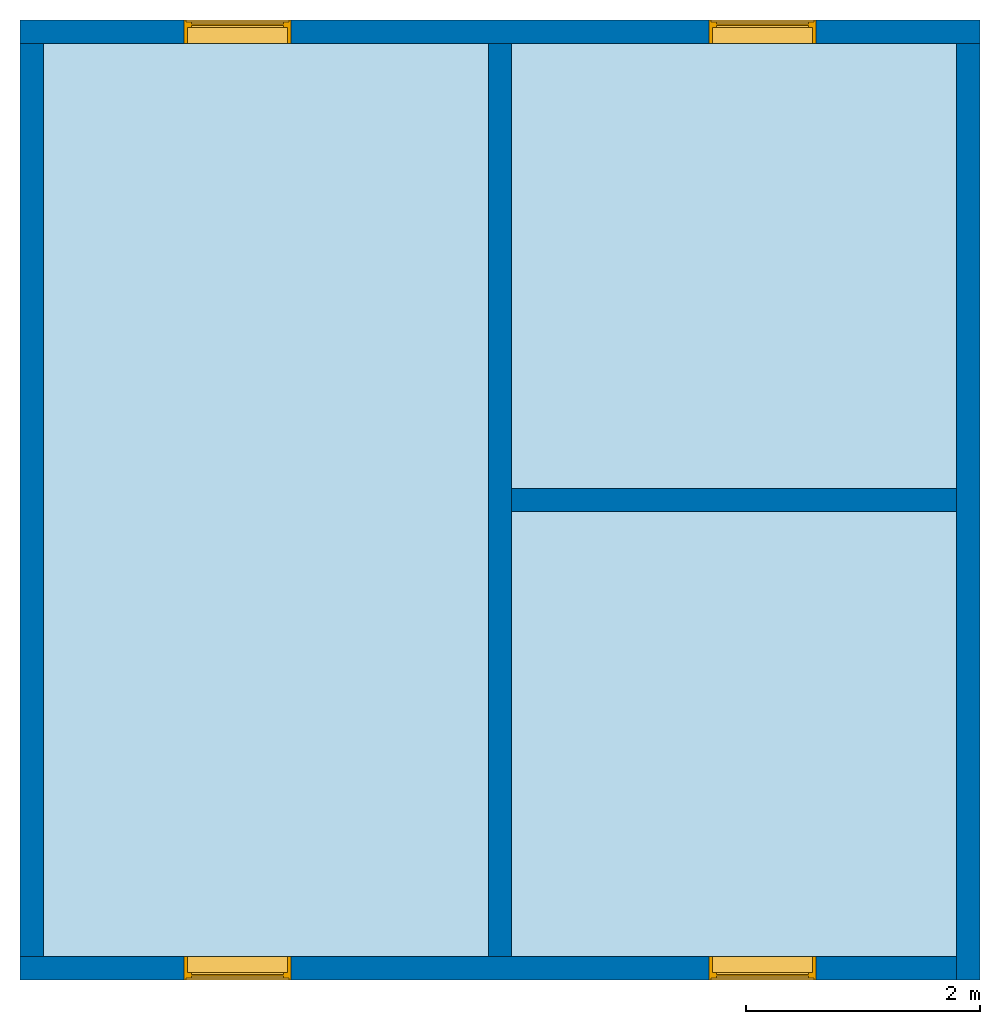
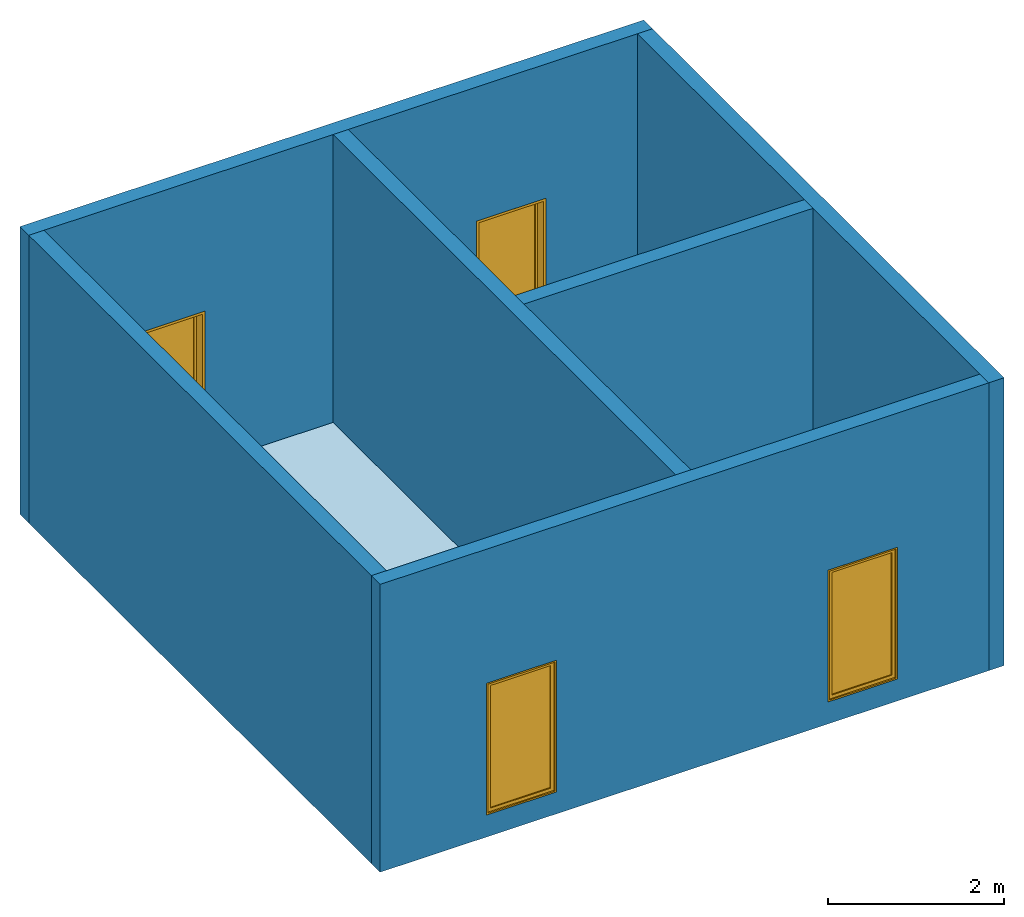
# One storey: 6 walls, 4 windows, 1 slab, 4 openings.
"""IFC2X3 building model written with IfcOpenShell, lengths in millimetres."""

import ifcopenshell
import ifcopenshell.guid

model = None  # the IFC model being written
_history = None  # IfcOwnerHistory: only IFC2X3 demands one
_inside = {}  # id of a spatial element -> (the spatial element, [elements in it])
_under = {}  # id of a project, library or spatial element -> (it, [spatial elements below it])
_declared = {}  # id of a project -> (the project, [libraries it declares])
_typed = {}  # id of a type object -> (the type object, [elements of that type])
_made_of = {}  # id of a material, layer set ... -> (it, [elements and type objects made of it])


def new_model(schema):
    """Start an empty IFC model of exactly this schema.

    Asked for "IFC4X3", IfcOpenShell would pick the latest addendum, in which some entities
    have other attributes; the version numbers below select the first issue.
    IFC2X3 requires an IfcOwnerHistory on every rooted entity: one is made here for all.
    """
    global model, _history
    if schema == "IFC4X3":
        model = ifcopenshell.file(schema_version=(4, 3, 0, 0))
    else:
        model = ifcopenshell.file(schema=schema)
    _inside.clear()
    _under.clear()
    _declared.clear()
    _typed.clear()
    _made_of.clear()
    _history = None
    if model.schema == "IFC2X3":
        org = make("IfcOrganization", Name="unknown")
        user = make(
            "IfcPersonAndOrganization",
            ThePerson=make("IfcPerson", FamilyName="unknown"),
            TheOrganization=org,
        )
        app = make(
            "IfcApplication",
            ApplicationDeveloper=org,
            Version="unknown",
            ApplicationFullName="unknown",
            ApplicationIdentifier="unknown",
        )
        _history = make(
            "IfcOwnerHistory",
            OwningUser=user,
            OwningApplication=app,
            ChangeAction="ADDED",
            CreationDate=0,
        )
    return model


def make(cls, **values):
    """One entity of the class cls with the attributes given. An attribute that is None is left unset."""
    return model.create_entity(
        cls, **{name: value for name, value in values.items() if value is not None}
    )


def entity(cls, *values):
    """Any entity or typed value of the class cls, its attributes in the order of the schema. None: left unset."""
    e = model.create_entity(cls)
    for i, value in enumerate(values):
        if value is not None:
            e[i] = value
    return e


def rooted(cls, **values):
    """An entity with a GlobalId (a new one), such as an element, a storey or a relation."""
    return make(cls, GlobalId=ifcopenshell.guid.new(), OwnerHistory=_history, **values)


def si_unit(unit_type, name, prefix=None):
    """IfcSIUnit, for example si_unit("LENGTHUNIT", "METRE", prefix="MILLI")."""
    return make("IfcSIUnit", UnitType=unit_type, Prefix=prefix, Name=name)


def converted_unit(unit_type, name, factor, base, dimensions=None, offset=None):
    """IfcConversionBasedUnit, such as the inch: factor (a typed value) times the base unit."""
    return make(
        "IfcConversionBasedUnit"
        if offset is None
        else "IfcConversionBasedUnitWithOffset",
        ConversionOffset=offset,
        Dimensions=None
        if dimensions is None
        else entity("IfcDimensionalExponents", *dimensions),
        UnitType=unit_type,
        Name=name,
        ConversionFactor=make(
            "IfcMeasureWithUnit", ValueComponent=factor, UnitComponent=base
        ),
    )


def derived_unit(unit_type, elements):
    """IfcDerivedUnit: a product of units, each with its exponent."""
    return make(
        "IfcDerivedUnit",
        Elements=[
            make("IfcDerivedUnitElement", Unit=unit, Exponent=power)
            for unit, power in elements
        ],
        UnitType=unit_type,
    )


def assignment(units):
    """IfcUnitAssignment: the units of a project."""
    return None if units is None else make("IfcUnitAssignment", Units=units)


def point(xyz):
    """IfcCartesianPoint."""
    return None if xyz is None else make("IfcCartesianPoint", Coordinates=xyz)


def direction(xyz):
    """IfcDirection."""
    return None if xyz is None else make("IfcDirection", DirectionRatios=xyz)


def frame(location, z_axis=None, x_axis=None):
    """IfcAxis2Placement3D, a coordinate frame: its origin and axes. An axis left out is left unset."""
    return make(
        "IfcAxis2Placement3D",
        Location=point(location),
        Axis=direction(z_axis),
        RefDirection=direction(x_axis),
    )


def frame_2d(location, x_axis=None):
    """IfcAxis2Placement2D, a coordinate frame in the plane: its origin and x axis."""
    return make(
        "IfcAxis2Placement2D", Location=point(location), RefDirection=direction(x_axis)
    )


def origin():
    """The frame at (0, 0, 0) with its axes left unset."""
    return frame((0.0, 0.0, 0.0))


def place(relative_to, where):
    """IfcLocalPlacement: puts the frame where relative to a parent placement (None: the world)."""
    return make(
        "IfcLocalPlacement", PlacementRelTo=relative_to, RelativePlacement=where
    )


def context(
    kind, dimensions, precision=None, world=None, true_north=None, identifier=None
):
    """IfcGeometricRepresentationContext, for example the 3D "Model" context."""
    return make(
        "IfcGeometricRepresentationContext",
        ContextIdentifier=identifier,
        ContextType=kind,
        CoordinateSpaceDimension=dimensions,
        Precision=precision,
        WorldCoordinateSystem=world,
        TrueNorth=true_north,
    )


def subcontext(parent, identifier, kind, view, scale=None):
    """IfcGeometricRepresentationSubContext, for example "Body" below "Model"."""
    return make(
        "IfcGeometricRepresentationSubContext",
        ContextIdentifier=identifier,
        ContextType=kind,
        ParentContext=parent,
        TargetScale=scale,
        TargetView=view,
    )


def project(units=None, contexts=None):
    """IfcProject with its units and contexts."""
    return rooted(
        "IfcProject",
        Name="project",
        RepresentationContexts=contexts,
        UnitsInContext=assignment(units),
    )


def spatial(cls, under=None, at=None, **own):
    """A site, building, storey or space (cls), placed at a placement, below another one or the project."""
    s = rooted(cls, ObjectPlacement=at, **own)
    if under is not None:
        _under.setdefault(under.id(), (under, []))[1].append(s)
    return s


def polyline(points):
    """IfcPolyline through the points."""
    return make("IfcPolyline", Points=[point(p) for p in points])


def profile(cls, at=None, kind="AREA", **sizes):
    """A parametric profile (cls). Its sizes go by their IFC names, for example OverallWidth=200.0."""
    return make(cls, ProfileType=kind, Position=at, **sizes)


def rectangle(**sizes):
    """IfcRectangleProfileDef."""
    return profile("IfcRectangleProfileDef", **sizes)


def outline(outer, holes=None, kind="AREA"):
    """IfcArbitraryClosedProfileDef: a profile drawn as a closed curve; with holes, ...WithVoids."""
    if holes is None:
        return make("IfcArbitraryClosedProfileDef", ProfileType=kind, OuterCurve=outer)
    return make(
        "IfcArbitraryProfileDefWithVoids",
        ProfileType=kind,
        OuterCurve=outer,
        InnerCurves=holes,
    )


def extrude(swept, where, along, depth):
    """IfcExtrudedAreaSolid: the profile swept, set in the frame where, extruded along a direction by depth."""
    return make(
        "IfcExtrudedAreaSolid",
        SweptArea=swept,
        Position=where,
        ExtrudedDirection=direction(along),
        Depth=depth,
    )


def clip(a, b, op="DIFFERENCE"):
    """IfcBooleanClippingResult: the solid a cut by the half space b."""
    return make(
        "IfcBooleanClippingResult", Operator=op, FirstOperand=a, SecondOperand=b
    )


def halfspace(plane, agree):
    """IfcHalfSpaceSolid: all space on one side of the plane z = 0 of the frame plane."""
    return make(
        "IfcHalfSpaceSolid",
        BaseSurface=make("IfcPlane", Position=plane),
        AgreementFlag=agree,
    )


def shape(context_of_items, identifier, shape_type, items):
    """IfcShapeRepresentation: the items that make up one representation, for example the "Body"."""
    return make(
        "IfcShapeRepresentation",
        ContextOfItems=context_of_items,
        RepresentationIdentifier=identifier,
        RepresentationType=shape_type,
        Items=items,
    )


def source(mapping_origin, context_of_items, identifier, shape_type, items):
    """IfcRepresentationMap: a shape defined once, which mapped items show again and again."""
    return make(
        "IfcRepresentationMap",
        MappingOrigin=mapping_origin,
        MappedRepresentation=shape(context_of_items, identifier, shape_type, items),
    )


def transform(
    local_origin,
    x_axis=None,
    y_axis=None,
    z_axis=None,
    scale=None,
    scale2=None,
    scale3=None,
    uniform=True,
):
    """IfcCartesianTransformationOperator3D, or its non-uniform kind. x_axis, y_axis, z_axis: its Axis1, 2, 3."""
    if uniform:
        return make(
            "IfcCartesianTransformationOperator3D",
            Axis1=direction(x_axis),
            Axis2=direction(y_axis),
            LocalOrigin=point(local_origin),
            Scale=scale,
            Axis3=direction(z_axis),
        )
    return make(
        "IfcCartesianTransformationOperator3DnonUniform",
        Axis1=direction(x_axis),
        Axis2=direction(y_axis),
        LocalOrigin=point(local_origin),
        Scale=scale,
        Axis3=direction(z_axis),
        Scale2=scale2,
        Scale3=scale3,
    )


def mapped(mapping_source, mapping_target):
    """IfcMappedItem: shows the shape of a source again, moved by a transform."""
    return make(
        "IfcMappedItem", MappingSource=mapping_source, MappingTarget=mapping_target
    )


def material(Name=None, Category=None):
    """IfcMaterial."""
    return make("IfcMaterial", Name=Name, Category=Category)


def material_list(materials):
    """IfcMaterialList."""
    return make("IfcMaterialList", Materials=materials)


def layer(
    of_material, thickness, ventilated=None, Name=None, Category=None, Priority=None
):
    """IfcMaterialLayer: one layer of a wall or slab, of a material (None: an air gap)."""
    return make(
        "IfcMaterialLayer",
        Material=of_material,
        LayerThickness=thickness,
        IsVentilated=ventilated,
        Name=Name,
        Category=Category,
        Priority=Priority,
    )


def layer_set(layers, Name=None):
    """IfcMaterialLayerSet."""
    return make("IfcMaterialLayerSet", MaterialLayers=layers, LayerSetName=Name)


def layer_usage(for_layer_set, set_direction, sense, offset, extent=None):
    """IfcMaterialLayerSetUsage: how a layer set lies in its element."""
    return make(
        "IfcMaterialLayerSetUsage",
        ForLayerSet=for_layer_set,
        LayerSetDirection=set_direction,
        DirectionSense=sense,
        OffsetFromReferenceLine=offset,
        ReferenceExtent=extent,
    )


def made_of(thing, what):
    """Note that an element or type object is made of a material, layer set ...; save() writes the relation."""
    if what is not None:
        _made_of.setdefault(what.id(), (what, []))[1].append(thing)
    return thing


def type_object(cls, material=None, **own):
    """A type object (cls), such as IfcWallType, which elements share."""
    return made_of(rooted(cls, **own), material)


def type_shapes(of_type, sources):
    """Give a type object the sources (RepresentationMaps) that its elements show as mapped items."""
    of_type.RepresentationMaps = sources


def element(
    cls,
    number,
    at=None,
    inside=None,
    cuts=None,
    type_object=None,
    material=None,
    context=None,
    identifier="Body",
    shape_type=None,
    held_by="IfcProductDefinitionShape",
    body=None,
    shapes=None,
    **own,
):
    """One element of the class cls, such as IfcWall. Its Tag is "e" and its number.

    at: its placement. inside: the storey or other place that contains it. cuts: it is an
    opening in that element (IfcRelVoidsElement). A single representation is given by context,
    identifier, shape_type and body (its items); several are given by shapes. held_by: the class
    of the entity that holds the representations. save() writes the other relations.
    """
    e = rooted(cls, Tag="e%d" % number, ObjectPlacement=at, **own)
    if body is not None:
        shapes = [shape(context, identifier, shape_type, body)]
    if shapes is not None:
        e.Representation = make(held_by, Representations=shapes)
    if inside is not None:
        _inside.setdefault(inside.id(), (inside, []))[1].append(e)
    if cuts is not None:
        rooted(
            "IfcRelVoidsElement", RelatingBuildingElement=cuts, RelatedOpeningElement=e
        )
    if type_object is not None:
        _typed.setdefault(type_object.id(), (type_object, []))[1].append(e)
    return made_of(e, material)


def fill(opening, filler):
    """IfcRelFillsElement: the door or window that sits in an opening."""
    return rooted(
        "IfcRelFillsElement",
        RelatingOpeningElement=opening,
        RelatedBuildingElement=filler,
    )


def aggregate(whole, parts):
    """IfcRelAggregates: a whole, such as a stair, and the parts it consists of."""
    return rooted("IfcRelAggregates", RelatingObject=whole, RelatedObjects=parts)


def save(model, path):
    """Write the relations noted so far, then the file.

    IfcRelAggregates (storeys below a building ...), IfcRelContainedInSpatialStructure (elements
    in a storey), IfcRelDefinesByType, IfcRelAssociatesMaterial and IfcRelDeclares: one each for
    every whole, place, type object, material and project.
    """
    for whole, parts in _under.values():
        aggregate(whole, parts)
    for where, things in _inside.values():
        rooted(
            "IfcRelContainedInSpatialStructure",
            RelatedElements=things,
            RelatingStructure=where,
        )
    for kind, things in _typed.values():
        rooted("IfcRelDefinesByType", RelatedObjects=things, RelatingType=kind)
    for what, things in _made_of.values():
        rooted("IfcRelAssociatesMaterial", RelatedObjects=things, RelatingMaterial=what)
    for by, libraries in _declared.values():
        rooted("IfcRelDeclares", RelatingContext=by, RelatedDefinitions=libraries)
    model.write(path)


model = new_model("IFC2X3")

# Units and contexts
model_context = context("Model", 3, precision=0.01, world=origin(), true_north=direction((6.12303176911189e-17, 1.0)))
body_context = subcontext(model_context, "Body", "Model", "MODEL_VIEW")
ifc_project = project(units=[si_unit("LENGTHUNIT", "METRE", prefix="MILLI"), si_unit("AREAUNIT", "SQUARE_METRE"), si_unit("VOLUMEUNIT", "CUBIC_METRE"), converted_unit("PLANEANGLEUNIT", "DEGREE", entity("IfcRatioMeasure", 0.0174532925199433), si_unit("PLANEANGLEUNIT", "RADIAN"), dimensions=[0, 0, 0, 0, 0, 0, 0]), si_unit("MASSUNIT", "GRAM", prefix="KILO"), derived_unit("MASSDENSITYUNIT", [(si_unit("MASSUNIT", "GRAM", prefix="KILO"), 1), (si_unit("LENGTHUNIT", "METRE"), -3)]), derived_unit("MOMENTOFINERTIAUNIT", [(si_unit("LENGTHUNIT", "METRE"), 4)]), si_unit("TIMEUNIT", "SECOND"), si_unit("FREQUENCYUNIT", "HERTZ"), si_unit("THERMODYNAMICTEMPERATUREUNIT", "DEGREE_CELSIUS"), derived_unit("THERMALTRANSMITTANCEUNIT", [(si_unit("MASSUNIT", "GRAM", prefix="KILO"), 1), (si_unit("THERMODYNAMICTEMPERATUREUNIT", "KELVIN"), -1), (si_unit("TIMEUNIT", "SECOND"), -3)]), derived_unit("VOLUMETRICFLOWRATEUNIT", [(si_unit("LENGTHUNIT", "METRE"), 3), (si_unit("TIMEUNIT", "SECOND"), -1)]), si_unit("ELECTRICCURRENTUNIT", "AMPERE"), si_unit("ELECTRICVOLTAGEUNIT", "VOLT"), si_unit("POWERUNIT", "WATT"), si_unit("FORCEUNIT", "NEWTON", prefix="KILO"), si_unit("ILLUMINANCEUNIT", "LUX"), si_unit("LUMINOUSFLUXUNIT", "LUMEN"), si_unit("LUMINOUSINTENSITYUNIT", "CANDELA"), derived_unit("USERDEFINED", [(si_unit("MASSUNIT", "GRAM", prefix="KILO"), -1), (si_unit("LENGTHUNIT", "METRE"), -2), (si_unit("TIMEUNIT", "SECOND"), 3), (si_unit("LUMINOUSFLUXUNIT", "LUMEN"), 1)]), derived_unit("LINEARVELOCITYUNIT", [(si_unit("LENGTHUNIT", "METRE"), 1), (si_unit("TIMEUNIT", "SECOND"), -1)]), si_unit("PRESSUREUNIT", "PASCAL"), derived_unit("USERDEFINED", [(si_unit("LENGTHUNIT", "METRE"), -2), (si_unit("MASSUNIT", "GRAM", prefix="KILO"), 1), (si_unit("TIMEUNIT", "SECOND"), -2)]), derived_unit("LINEARFORCEUNIT", [(si_unit("MASSUNIT", "GRAM", prefix="KILO"), 1), (si_unit("LENGTHUNIT", "METRE"), 1), (si_unit("TIMEUNIT", "SECOND"), -2), (si_unit("LENGTHUNIT", "METRE"), -1)]), derived_unit("PLANARFORCEUNIT", [(si_unit("MASSUNIT", "GRAM", prefix="KILO"), 1), (si_unit("LENGTHUNIT", "METRE"), 1), (si_unit("TIMEUNIT", "SECOND"), -2), (si_unit("LENGTHUNIT", "METRE"), -2)])], contexts=[model_context])

# Site, building, storey
site_placement = place(None, origin())
site = spatial("IfcSite", under=ifc_project, at=site_placement, CompositionType="ELEMENT")
building_placement = place(site_placement, origin())
building = spatial("IfcBuilding", under=site, at=building_placement, Name="// BUILDING/NAME //", CompositionType="ELEMENT")
storey_placement = place(building_placement, frame((0.0, 0.0, 8000.0)))
storey = spatial("IfcBuildingStorey", under=building, at=storey_placement, Name="Level 4", CompositionType="ELEMENT", Elevation=8000.0)

# Slab
ifc_material_1 = material(Name="Default Floor")
ifc_layer_1 = layer(ifc_material_1, 150.0)
ifc_layer_set_1 = layer_set([ifc_layer_1], Name="Floor:Generic 150mm")
ifc_layer_usage_1 = layer_usage(ifc_layer_set_1, "AXIS3", "POSITIVE", 0.0)
slab_type = type_object("IfcSlabType", Name="Floor:Generic 150mm", PredefinedType="FLOOR", material=ifc_layer_set_1)
slab_placement = place(storey_placement, origin())
element("IfcSlab", 1, at=slab_placement, inside=storey, type_object=slab_type, material=ifc_layer_usage_1, Name="Floor:Generic 150mm", ObjectType="Floor:Generic 150mm", PredefinedType="FLOOR", context=body_context, shape_type="SweptSolid", body=[
    extrude(rectangle(XDim=7800.0, YDim=7800.00000000005, at=frame_2d((2.27373675443232e-13, -3.18323145620525e-12), x_axis=(1.0, 0.0))), frame((-1771.27800988199, -3876.69891580694, 0.0), z_axis=(0.0, 0.0, -1.0), x_axis=(0.0, 1.0, 0.0)), (0.0, 0.0, 1.0), 149.999999999999),
])

# Wall, openings, windows
ifc_material_2 = material(Name="Default Wall")
ifc_layer_2 = layer(ifc_material_2, 200.0)
ifc_layer_set_2 = layer_set([ifc_layer_2], Name="Basic Wall:Outside wall")
ifc_layer_usage_2 = layer_usage(ifc_layer_set_2, "AXIS2", "NEGATIVE", 100.0)
wall_type_1 = type_object("IfcWallType", Name="Basic Wall:Outside wall", PredefinedType="STANDARD", material=ifc_layer_set_2)
wall_1_placement = place(storey_placement, frame((-5871.27800988201, 123.301084193077, 0.0)))
wall_1 = element("IfcWallStandardCase", 2, at=wall_1_placement, inside=storey, type_object=wall_type_1, material=ifc_layer_usage_2, Name="Basic Wall:Outside wall", ObjectType="Basic Wall:Outside wall", context=body_context, shape_type="Clipping", body=[
    clip(extrude(rectangle(XDim=8200.00000000003, YDim=200.0, at=frame_2d((4100.00000000002, 0.0), x_axis=(-1.0, 0.0))), origin(), (0.0, 0.0, 1.0), 4000.0), halfspace(frame((0.0, 0.0, -8000.0)), True)),
])
opening_1_placement = place(wall_1_placement, frame((5885.0, -100.0, 305.0)))
opening_1 = element("IfcOpeningElement", 3, at=opening_1_placement, cuts=wall_1, Name="M_Fixed:0915 x 1830mm:1", ObjectType="Opening", context=body_context, shape_type="SweptSolid", body=[
    extrude(rectangle(XDim=1830.0, YDim=914.999999999999, at=frame_2d((914.999999999999, 457.499999999999), x_axis=(1.0, 0.0))), frame((0.0, 0.0, 0.0), z_axis=(0.0, 1.0, 0.0), x_axis=(0.0, 0.0, 1.0)), (0.0, 0.0, 1.0), 200.0),
])
opening_2_placement = place(wall_1_placement, frame((1400.0, -100.0, 305.0)))
opening_2 = element("IfcOpeningElement", 4, at=opening_2_placement, cuts=wall_1, Name="M_Fixed:0915 x 1830mm:1", ObjectType="Opening", context=body_context, shape_type="SweptSolid", body=[
    extrude(rectangle(XDim=1830.0, YDim=914.999999999999, at=frame_2d((914.999999999999, 457.5), x_axis=(1.0, 0.0))), frame((0.0, 0.0, 0.0), z_axis=(0.0, 1.0, 0.0), x_axis=(0.0, 0.0, 1.0)), (0.0, 0.0, 1.0), 200.0),
])
ifc_material_3 = material(Name="Glass")
ifc_material_4 = material(Name="Sash")
ifc_material_list_1 = material_list([ifc_material_3, ifc_material_4])
ifc_material_list_2 = material_list([ifc_material_4, ifc_material_4, ifc_material_4, ifc_material_3])
window_style = type_object("IfcWindowStyle", Name="M_Fixed:0915 x 1830mm", ConstructionType="NOTDEFINED", OperationType="NOTDEFINED", ParameterTakesPrecedence=False, Sizeable=False, material=ifc_material_list_2)
shared_shape = source(origin(), body_context, "Body", "SweptSolid", [
    extrude(rectangle(XDim=12.0, YDim=788.999999999997, at=frame_2d((8.43769498715119e-15, 0.0), x_axis=(1.0, 0.0))), frame((457.500000000006, 159.0, 63.0), z_axis=(0.0, 0.0, 1.0), x_axis=(0.0, -1.0, 0.0)), (0.0, 0.0, 1.0), 1704.00000000001),
    extrude(outline(polyline([(-438.5, -896.0), (438.5, -896.0), (438.5, 896.0), (-438.5, 896.0), (-438.5, -896.0)]), holes=[polyline([(-394.5, -852.0), (-394.5, 852.0), (394.499999999998, 852.0), (394.499999999998, -852.0), (-394.5, -852.0)])]), frame((457.500000000007, 137.0, 915.0), z_axis=(0.0, 1.0, 0.0), x_axis=(1.0, 0.0, 0.0)), (0.0, 0.0, 1.0), 44.0000000000274),
    extrude(outline(polyline([(-457.5, -915.0), (457.5, -915.0), (457.5, 915.0), (-457.5, 915.0), (-457.5, -915.0)]), holes=[polyline([(-438.500000000001, -896.0), (-438.500000000001, 896.0), (438.499999999999, 896.0), (438.499999999999, -896.0), (-438.500000000001, -896.0)])]), frame((457.500000000008, 137.0, 915.0), z_axis=(0.0, 1.0, 0.0), x_axis=(1.0, 0.0, 0.0)), (0.0, 0.0, 1.0), 63.0000000000274),
    extrude(outline(polyline([(-457.5, -915.0), (457.5, -915.0), (457.5, 915.0), (-457.5, 915.0), (-457.5, -915.0)]), holes=[polyline([(-425.5, -883.0), (-425.5, 883.0), (425.5, 883.0), (425.5, -883.0), (-425.5, -883.0)])]), frame((457.500000000008, 0.0, 915.0), z_axis=(0.0, 1.0, 0.0), x_axis=(1.0, 0.0, 0.0)), (0.0, 0.0, 1.0), 136.999999999973),
])
type_shapes(window_style, [shared_shape])
window_1_placement = place(opening_1_placement, origin())
window_1 = element("IfcWindow", 5, at=window_1_placement, inside=storey, type_object=window_style, material=ifc_material_list_1, Name="M_Fixed:0915 x 1830mm", ObjectType="M_Fixed:0915 x 1830mm", OverallHeight=1830.0, OverallWidth=915.0, context=body_context, shape_type="MappedRepresentation", body=[
    mapped(shared_shape, transform((0.0, 0.0, 0.0), scale=1.0)),
])
fill(opening_1, window_1)
ifc_material_list_3 = material_list([ifc_material_3, ifc_material_4])
window_2_placement = place(opening_2_placement, origin())
window_2 = element("IfcWindow", 6, at=window_2_placement, inside=storey, type_object=window_style, material=ifc_material_list_3, Name="M_Fixed:0915 x 1830mm", ObjectType="M_Fixed:0915 x 1830mm", OverallHeight=1830.0, OverallWidth=914.999999999999, context=body_context, shape_type="MappedRepresentation", body=[
    mapped(shared_shape, transform((0.0, 0.0, 0.0), scale=1.0)),
])
fill(opening_2, window_2)

# Wall
ifc_layer_usage_3 = layer_usage(ifc_layer_set_2, "AXIS2", "NEGATIVE", 100.0)
wall_2_placement = place(storey_placement, frame((2228.72199011802, 23.3010841930509, 0.0), z_axis=(0.0, 0.0, 1.0), x_axis=(0.0, -1.0, 0.0)))
element("IfcWallStandardCase", 7, at=wall_2_placement, inside=storey, type_object=wall_type_1, material=ifc_layer_usage_3, Name="Basic Wall:Outside wall", ObjectType="Basic Wall:Outside wall", context=body_context, shape_type="Clipping", body=[
    clip(extrude(rectangle(XDim=8000.0, YDim=200.0, at=frame_2d((4000.0, 0.0), x_axis=(-1.0, 0.0))), origin(), (0.0, 0.0, 1.0), 4000.0), halfspace(frame((0.0, 0.0, -8000.0)), True)),
])

# Wall, openings, windows
ifc_layer_usage_4 = layer_usage(ifc_layer_set_2, "AXIS2", "NEGATIVE", 100.0)
wall_3_placement = place(storey_placement, frame((2128.72199011802, -7876.69891580695, 0.0), z_axis=(0.0, 0.0, 1.0), x_axis=(-1.0, 0.0, 0.0)))
wall_3 = element("IfcWallStandardCase", 8, at=wall_3_placement, inside=storey, type_object=wall_type_1, material=ifc_layer_usage_4, Name="Basic Wall:Outside wall", ObjectType="Basic Wall:Outside wall", context=body_context, shape_type="Clipping", body=[
    clip(extrude(rectangle(XDim=8000.00000000005, YDim=200.0, at=frame_2d((4000.00000000002, 0.0), x_axis=(-1.0, 0.0))), origin(), (0.0, 0.0, 1.0), 4000.0), halfspace(frame((0.0, 0.0, -8000.0)), True)),
])
opening_3_placement = place(wall_3_placement, frame((5685.0, -100.0, 305.0)))
opening_3 = element("IfcOpeningElement", 9, at=opening_3_placement, cuts=wall_3, Name="M_Fixed:0915 x 1830mm:1", ObjectType="Opening", context=body_context, shape_type="SweptSolid", body=[
    extrude(rectangle(XDim=1830.0, YDim=914.999999999999, at=frame_2d((914.999999999999, 457.499999999999), x_axis=(1.0, 0.0))), frame((0.0, 0.0, 0.0), z_axis=(0.0, 1.0, 0.0), x_axis=(0.0, 0.0, 1.0)), (0.0, 0.0, 1.0), 200.0),
])
opening_4_placement = place(wall_3_placement, frame((1200.0, -100.0, 305.0)))
opening_4 = element("IfcOpeningElement", 10, at=opening_4_placement, cuts=wall_3, Name="M_Fixed:0915 x 1830mm:1", ObjectType="Opening", context=body_context, shape_type="SweptSolid", body=[
    extrude(rectangle(XDim=1830.0, YDim=914.999999999999, at=frame_2d((914.999999999999, 457.5), x_axis=(1.0, 0.0))), frame((0.0, 0.0, 0.0), z_axis=(0.0, 1.0, 0.0), x_axis=(0.0, 0.0, 1.0)), (0.0, 0.0, 1.0), 200.0),
])
ifc_material_list_4 = material_list([ifc_material_3, ifc_material_4])
window_3_placement = place(opening_3_placement, origin())
window_3 = element("IfcWindow", 11, at=window_3_placement, inside=storey, type_object=window_style, material=ifc_material_list_4, Name="M_Fixed:0915 x 1830mm", ObjectType="M_Fixed:0915 x 1830mm", OverallHeight=1830.0, OverallWidth=914.999999999999, context=body_context, shape_type="MappedRepresentation", body=[
    mapped(shared_shape, transform((0.0, 0.0, 0.0), scale=1.0)),
])
fill(opening_3, window_3)
ifc_material_list_5 = material_list([ifc_material_3, ifc_material_4])
window_4_placement = place(opening_4_placement, origin())
window_4 = element("IfcWindow", 12, at=window_4_placement, inside=storey, type_object=window_style, material=ifc_material_list_5, Name="M_Fixed:0915 x 1830mm", ObjectType="M_Fixed:0915 x 1830mm", OverallHeight=1830.0, OverallWidth=914.999999999999, context=body_context, shape_type="MappedRepresentation", body=[
    mapped(shared_shape, transform((0.0, 0.0, 0.0), scale=1.0)),
])
fill(opening_4, window_4)

# Walls
ifc_layer_usage_5 = layer_usage(ifc_layer_set_2, "AXIS2", "NEGATIVE", 100.0)
wall_4_placement = place(storey_placement, frame((-5771.27800988202, -7776.69891580692, 0.0), z_axis=(0.0, 0.0, 1.0), x_axis=(0.0, 1.0, 0.0)))
element("IfcWallStandardCase", 13, at=wall_4_placement, inside=storey, type_object=wall_type_1, material=ifc_layer_usage_5, Name="Basic Wall:Outside wall", ObjectType="Basic Wall:Outside wall", context=body_context, shape_type="Clipping", body=[
    clip(extrude(rectangle(XDim=7800.0, YDim=200.0, at=frame_2d((3900.0, -1.56319401867222e-13), x_axis=(-1.0, 0.0))), origin(), (0.0, 0.0, 1.0), 4000.0), halfspace(frame((0.0, 0.0, -8000.0)), True)),
])
ifc_layer_3 = layer(ifc_material_2, 200.0)
ifc_layer_set_3 = layer_set([ifc_layer_3], Name="Basic Wall:Inside")
ifc_layer_usage_6 = layer_usage(ifc_layer_set_3, "AXIS2", "NEGATIVE", 100.0)
wall_type_2 = type_object("IfcWallType", Name="Basic Wall:Inside", PredefinedType="STANDARD", material=ifc_layer_set_3)
wall_5_placement = place(storey_placement, frame((-1771.27800988198, 23.3010841930636, 0.0), z_axis=(0.0, 0.0, 1.0), x_axis=(0.0, -1.0, 0.0)))
element("IfcWallStandardCase", 14, at=wall_5_placement, inside=storey, type_object=wall_type_2, material=ifc_layer_usage_6, Name="Basic Wall:Inside", ObjectType="Basic Wall:Inside", context=body_context, shape_type="Clipping", body=[
    clip(extrude(rectangle(XDim=7800.0, YDim=200.0, at=frame_2d((3900.0, 1.13686837721616e-13), x_axis=(-1.0, 0.0))), origin(), (0.0, 0.0, 1.0), 4000.0), halfspace(frame((0.0, 0.0, -8000.0)), True)),
])
ifc_layer_usage_7 = layer_usage(ifc_layer_set_3, "AXIS2", "NEGATIVE", 100.0)
wall_6_placement = place(storey_placement, frame((-1671.27800988198, -3876.69891580694, 0.0)))
element("IfcWallStandardCase", 15, at=wall_6_placement, inside=storey, type_object=wall_type_2, material=ifc_layer_usage_7, Name="Basic Wall:Inside", ObjectType="Basic Wall:Inside", context=body_context, shape_type="Clipping", body=[
    clip(extrude(rectangle(XDim=3800.00000000001, YDim=200.0, at=frame_2d((1900.0, 2.20268248085631e-13), x_axis=(-1.0, 0.0))), origin(), (0.0, 0.0, 1.0), 4000.0), halfspace(frame((0.0, 0.0, -8000.0)), True)),
])

save(model, "model.ifc")
